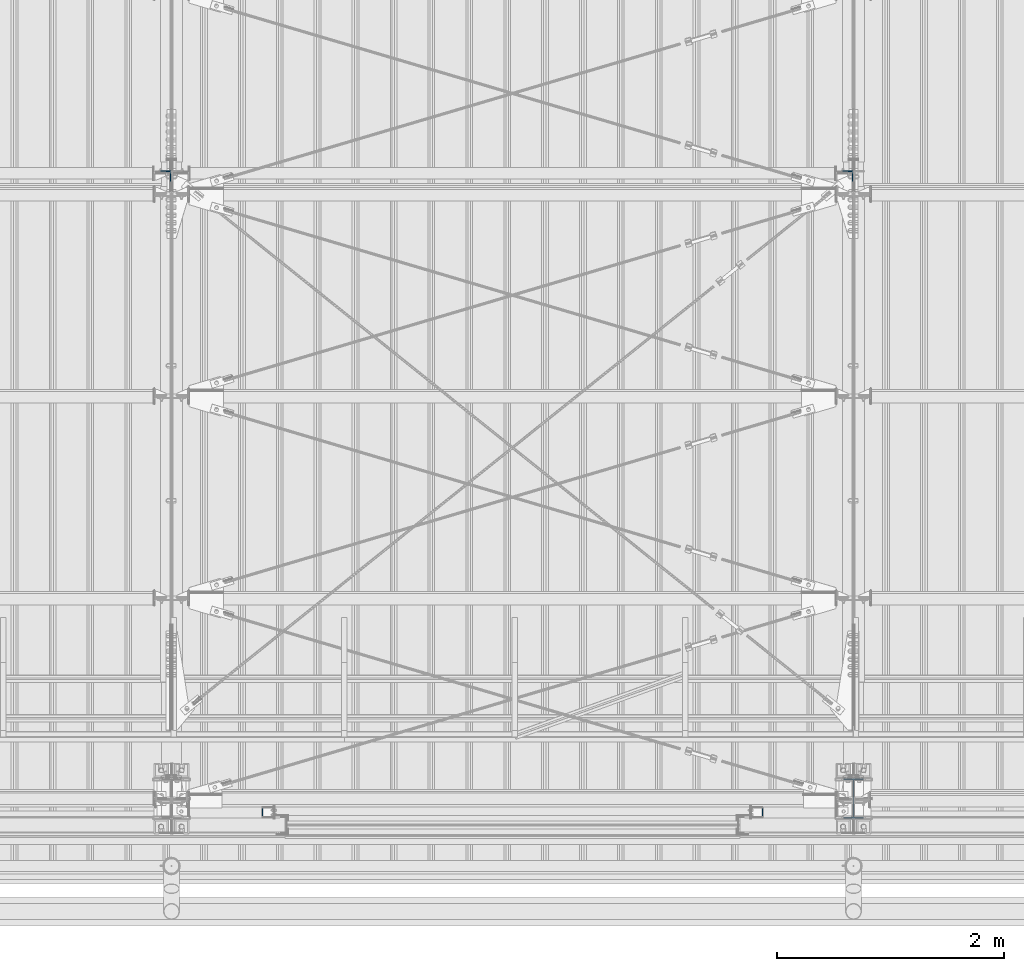
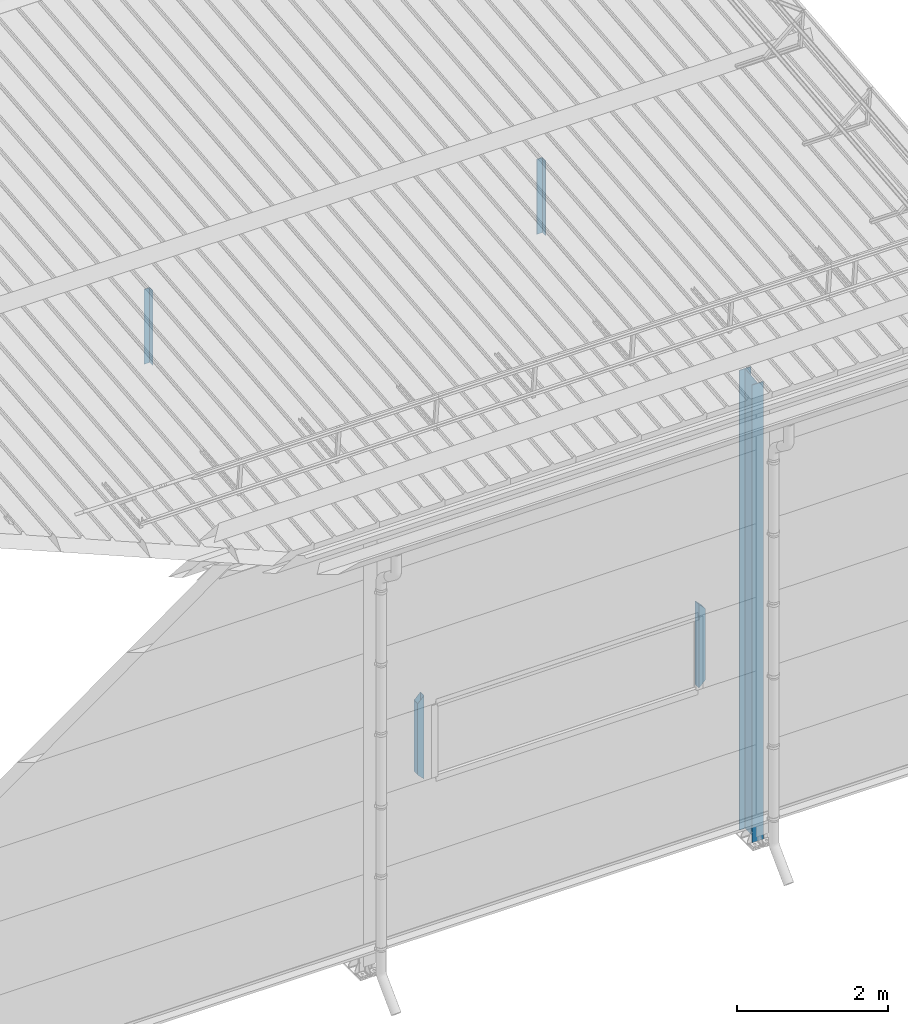
# One storey, part 235 of 709: 5 columns, 5 elements without a shape of their own.
"""IFC4 building model written with IfcOpenShell, lengths in millimetres."""

import ifcopenshell
import ifcopenshell.guid

model = None  # the IFC model being written
_history = None  # IfcOwnerHistory: only IFC2X3 demands one
_inside = {}  # id of a spatial element -> (the spatial element, [elements in it])
_under = {}  # id of a project, library or spatial element -> (it, [spatial elements below it])
_declared = {}  # id of a project -> (the project, [libraries it declares])
_typed = {}  # id of a type object -> (the type object, [elements of that type])
_made_of = {}  # id of a material, layer set ... -> (it, [elements and type objects made of it])


def new_model(schema):
    """Start an empty IFC model of exactly this schema.

    Asked for "IFC4X3", IfcOpenShell would pick the latest addendum, in which some entities
    have other attributes; the version numbers below select the first issue.
    IFC2X3 requires an IfcOwnerHistory on every rooted entity: one is made here for all.
    """
    global model, _history
    if schema == "IFC4X3":
        model = ifcopenshell.file(schema_version=(4, 3, 0, 0))
    else:
        model = ifcopenshell.file(schema=schema)
    _inside.clear()
    _under.clear()
    _declared.clear()
    _typed.clear()
    _made_of.clear()
    _history = None
    if model.schema == "IFC2X3":
        org = make("IfcOrganization", Name="unknown")
        user = make(
            "IfcPersonAndOrganization",
            ThePerson=make("IfcPerson", FamilyName="unknown"),
            TheOrganization=org,
        )
        app = make(
            "IfcApplication",
            ApplicationDeveloper=org,
            Version="unknown",
            ApplicationFullName="unknown",
            ApplicationIdentifier="unknown",
        )
        _history = make(
            "IfcOwnerHistory",
            OwningUser=user,
            OwningApplication=app,
            ChangeAction="ADDED",
            CreationDate=0,
        )
    return model


def make(cls, **values):
    """One entity of the class cls with the attributes given. An attribute that is None is left unset."""
    return model.create_entity(
        cls, **{name: value for name, value in values.items() if value is not None}
    )


def rooted(cls, **values):
    """An entity with a GlobalId (a new one), such as an element, a storey or a relation."""
    return make(cls, GlobalId=ifcopenshell.guid.new(), OwnerHistory=_history, **values)


def si_unit(unit_type, name, prefix=None):
    """IfcSIUnit, for example si_unit("LENGTHUNIT", "METRE", prefix="MILLI")."""
    return make("IfcSIUnit", UnitType=unit_type, Prefix=prefix, Name=name)


def assignment(units):
    """IfcUnitAssignment: the units of a project."""
    return None if units is None else make("IfcUnitAssignment", Units=units)


def point(xyz):
    """IfcCartesianPoint."""
    return None if xyz is None else make("IfcCartesianPoint", Coordinates=xyz)


def direction(xyz):
    """IfcDirection."""
    return None if xyz is None else make("IfcDirection", DirectionRatios=xyz)


def frame(location, z_axis=None, x_axis=None):
    """IfcAxis2Placement3D, a coordinate frame: its origin and axes. An axis left out is left unset."""
    return make(
        "IfcAxis2Placement3D",
        Location=point(location),
        Axis=direction(z_axis),
        RefDirection=direction(x_axis),
    )


def origin_with_axes():
    """The frame at (0, 0, 0) with the z axis (0, 0, 1) and the x axis (1, 0, 0) written out."""
    return frame((0.0, 0.0, 0.0), z_axis=(0.0, 0.0, 1.0), x_axis=(1.0, 0.0, 0.0))


def place(relative_to, where):
    """IfcLocalPlacement: puts the frame where relative to a parent placement (None: the world)."""
    return make(
        "IfcLocalPlacement", PlacementRelTo=relative_to, RelativePlacement=where
    )


def context(
    kind, dimensions, precision=None, world=None, true_north=None, identifier=None
):
    """IfcGeometricRepresentationContext, for example the 3D "Model" context."""
    return make(
        "IfcGeometricRepresentationContext",
        ContextIdentifier=identifier,
        ContextType=kind,
        CoordinateSpaceDimension=dimensions,
        Precision=precision,
        WorldCoordinateSystem=world,
        TrueNorth=true_north,
    )


def subcontext(parent, identifier, kind, view, scale=None):
    """IfcGeometricRepresentationSubContext, for example "Body" below "Model"."""
    return make(
        "IfcGeometricRepresentationSubContext",
        ContextIdentifier=identifier,
        ContextType=kind,
        ParentContext=parent,
        TargetScale=scale,
        TargetView=view,
    )


def project(units=None, contexts=None):
    """IfcProject with its units and contexts."""
    return rooted(
        "IfcProject",
        Name="project",
        RepresentationContexts=contexts,
        UnitsInContext=assignment(units),
    )


def spatial(cls, under=None, at=None, **own):
    """A site, building, storey or space (cls), placed at a placement, below another one or the project."""
    s = rooted(cls, ObjectPlacement=at, **own)
    if under is not None:
        _under.setdefault(under.id(), (under, []))[1].append(s)
    return s


def point_list(points):
    """IfcCartesianPointList2D or 3D."""
    cls = (
        "IfcCartesianPointList2D" if len(points[0]) == 2 else "IfcCartesianPointList3D"
    )
    return make(cls, CoordList=points)


def polygons(points, faces, closed=None, point_numbers=None):
    """IfcPolygonalFaceSet: a face is its outer loop, then its inner loops; points numbered from 1."""
    made = []
    for loops in faces:
        if len(loops) == 1:
            made.append(make("IfcIndexedPolygonalFace", CoordIndex=loops[0]))
        else:
            made.append(
                make(
                    "IfcIndexedPolygonalFaceWithVoids",
                    CoordIndex=loops[0],
                    InnerCoordIndices=loops[1:],
                )
            )
    return make(
        "IfcPolygonalFaceSet",
        Coordinates=point_list(points),
        Closed=closed,
        Faces=made,
        PnIndex=point_numbers,
    )


def shape(context_of_items, identifier, shape_type, items):
    """IfcShapeRepresentation: the items that make up one representation, for example the "Body"."""
    return make(
        "IfcShapeRepresentation",
        ContextOfItems=context_of_items,
        RepresentationIdentifier=identifier,
        RepresentationType=shape_type,
        Items=items,
    )


def material(Name=None, Category=None):
    """IfcMaterial."""
    return make("IfcMaterial", Name=Name, Category=Category)


def made_of(thing, what):
    """Note that an element or type object is made of a material, layer set ...; save() writes the relation."""
    if what is not None:
        _made_of.setdefault(what.id(), (what, []))[1].append(thing)
    return thing


def element(
    cls,
    number,
    at=None,
    inside=None,
    cuts=None,
    type_object=None,
    material=None,
    context=None,
    identifier="Body",
    shape_type=None,
    held_by="IfcProductDefinitionShape",
    body=None,
    shapes=None,
    **own,
):
    """One element of the class cls, such as IfcWall. Its Tag is "e" and its number.

    at: its placement. inside: the storey or other place that contains it. cuts: it is an
    opening in that element (IfcRelVoidsElement). A single representation is given by context,
    identifier, shape_type and body (its items); several are given by shapes. held_by: the class
    of the entity that holds the representations. save() writes the other relations.
    """
    e = rooted(cls, Tag="e%d" % number, ObjectPlacement=at, **own)
    if body is not None:
        shapes = [shape(context, identifier, shape_type, body)]
    if shapes is not None:
        e.Representation = make(held_by, Representations=shapes)
    if inside is not None:
        _inside.setdefault(inside.id(), (inside, []))[1].append(e)
    if cuts is not None:
        rooted(
            "IfcRelVoidsElement", RelatingBuildingElement=cuts, RelatedOpeningElement=e
        )
    if type_object is not None:
        _typed.setdefault(type_object.id(), (type_object, []))[1].append(e)
    return made_of(e, material)


def aggregate(whole, parts):
    """IfcRelAggregates: a whole, such as a stair, and the parts it consists of."""
    return rooted("IfcRelAggregates", RelatingObject=whole, RelatedObjects=parts)


def save(model, path):
    """Write the relations noted so far, then the file.

    IfcRelAggregates (storeys below a building ...), IfcRelContainedInSpatialStructure (elements
    in a storey), IfcRelDefinesByType, IfcRelAssociatesMaterial and IfcRelDeclares: one each for
    every whole, place, type object, material and project.
    """
    for whole, parts in _under.values():
        aggregate(whole, parts)
    for where, things in _inside.values():
        rooted(
            "IfcRelContainedInSpatialStructure",
            RelatedElements=things,
            RelatingStructure=where,
        )
    for kind, things in _typed.values():
        rooted("IfcRelDefinesByType", RelatedObjects=things, RelatingType=kind)
    for what, things in _made_of.values():
        rooted("IfcRelAssociatesMaterial", RelatedObjects=things, RelatingMaterial=what)
    for by, libraries in _declared.values():
        rooted("IfcRelDeclares", RelatingContext=by, RelatedDefinitions=libraries)
    model.write(path)


model = new_model("IFC4")

# Units and contexts
model_context = context("Model", 3, precision=0.2, world=origin_with_axes(), true_north=direction((0.0, 1.0)))
body_context = subcontext(model_context, "Body", "Model", "MODEL_VIEW")
ifc_project = project(units=[si_unit("LENGTHUNIT", "METRE", prefix="MILLI"), si_unit("AREAUNIT", "SQUARE_METRE"), si_unit("VOLUMEUNIT", "CUBIC_METRE"), si_unit("MASSUNIT", "GRAM", prefix="KILO"), si_unit("TIMEUNIT", "SECOND"), si_unit("PLANEANGLEUNIT", "RADIAN"), si_unit("SOLIDANGLEUNIT", "STERADIAN"), si_unit("THERMODYNAMICTEMPERATUREUNIT", "DEGREE_CELSIUS"), si_unit("LUMINOUSINTENSITYUNIT", "LUMEN")], contexts=[model_context])

# Site, building, storey
site_placement = place(None, origin_with_axes())
site = spatial("IfcSite", under=ifc_project, at=site_placement, CompositionType="ELEMENT")
building_placement = place(site_placement, origin_with_axes())
building = spatial("IfcBuilding", under=site, at=building_placement, Name="Undefined", CompositionType="ELEMENT")
storey_placement = place(building_placement, origin_with_axes())
storey = spatial("IfcBuildingStorey", under=building, at=storey_placement, Name="Undefined", CompositionType="ELEMENT", Elevation=0.0)

# Assembly, column
assembly_1_placement = place(storey_placement, frame((46000.0, 173.0, -200.0), z_axis=(-1.0, 0.0, 0.0), x_axis=(0.0, 0.0, 1.0)))
assembly_1 = element("IfcElementAssembly", 1, at=assembly_1_placement, inside=storey)
ifc_material_1 = material(Name="C355-5", Category="STEEL")
column_1_placement = place(assembly_1_placement, origin_with_axes())
column_1 = element("IfcColumn", 2, at=column_1_placement, material=ifc_material_1, ObjectType="413", context=body_context, shape_type="Tessellation", body=[
    polygons([(25.0, -173.0, -87.0), (25.0, -164.0, -87.0), (7421.82297, -164.0, -87.0), (7420.92297, -173.0, -87.0), (25.0, -164.0, -3.0), (7421.82297, -164.0, -3.0), (25.0, 164.0, -3.0), (7454.62297, 164.0, -3.0), (25.0, 164.0, -87.0), (7454.62297, 164.0, -87.0), (25.0, 173.0, -87.0), (7455.52297, 173.0, -87.0), (25.0, 173.0, 87.0), (7455.52297, 173.0, 87.0), (25.0, 164.0, 87.0), (7454.62297, 164.0, 87.0), (25.0, 164.0, 3.0), (7454.62297, 164.0, 3.0), (25.0, -164.0, 3.0), (7421.82297, -164.0, 3.0), (25.0, -164.0, 87.0), (7421.82297, -164.0, 87.0), (25.0, -173.0, 87.0), (7420.92297, -173.0, 87.0)], [[[1, 2, 3, 4]], [[2, 5, 6, 3]], [[5, 7, 8, 6]], [[7, 9, 10, 8]], [[9, 11, 12, 10]], [[11, 13, 14, 12]], [[13, 15, 16, 14]], [[15, 17, 18, 16]], [[17, 19, 20, 18]], [[19, 21, 22, 20]], [[21, 23, 24, 22]], [[23, 1, 4, 24]], [[6, 8, 10, 12, 14, 16, 18, 20, 22, 24, 4, 3]], [[23, 21, 19, 17, 15, 13, 11, 9, 7, 5, 2, 1]]], closed=True),
])
aggregate(assembly_1, [column_1])

assembly_2_placement = place(storey_placement, frame((39949.0, 5648.7, 6024.30002), z_axis=(0.0, -1.0, 0.0), x_axis=(0.0, 0.0, 1.0)))
assembly_2 = element("IfcElementAssembly", 3, at=assembly_2_placement, inside=storey)
ifc_material_2 = material(Name="C345-5", Category="STEEL")
column_2_placement = place(assembly_2_placement, origin_with_axes())
column_2 = element("IfcColumn", 4, at=column_2_placement, material=ifc_material_2, ObjectType="436", context=body_context, shape_type="Tessellation", body=[
    polygons([(185.7, -45.0, -45.0), (185.7, 45.0, -45.0), (1399.0509, 45.0, -45.0), (1399.0509, -45.0, -45.0), (185.7, 45.0, -39.0), (1399.0509, 45.0, -39.0), (185.7, -39.0, -39.0), (1399.0509, -39.0, -39.0), (185.7, -39.0, 45.0), (1399.0509, -39.0, 45.0), (185.7, -45.0, 45.0), (1399.0509, -45.0, 45.0)], [[[1, 2, 3, 4]], [[2, 5, 6, 3]], [[5, 7, 8, 6]], [[7, 9, 10, 8]], [[9, 11, 12, 10]], [[11, 1, 4, 12]], [[6, 8, 10, 12, 4, 3]], [[11, 9, 7, 5, 2, 1]]], closed=True),
])
aggregate(assembly_2, [column_2])

assembly_3_placement = place(storey_placement, frame((45949.0, 5648.7, 6024.30002), z_axis=(0.0, -1.0, 0.0), x_axis=(0.0, 0.0, 1.0)))
assembly_3 = element("IfcElementAssembly", 5, at=assembly_3_placement, inside=storey)
column_3_placement = place(assembly_3_placement, origin_with_axes())
column_3 = element("IfcColumn", 6, at=column_3_placement, material=ifc_material_2, ObjectType="436", context=body_context, shape_type="Tessellation", body=[
    polygons([(185.7, -45.0, -45.0), (185.7, 45.0, -45.0), (1399.0509, 45.0, -45.0), (1399.0509, -45.0, -45.0), (185.7, 45.0, -39.0), (1399.0509, 45.0, -39.0), (185.7, -39.0, -39.0), (1399.0509, -39.0, -39.0), (185.7, -39.0, 45.0), (1399.0509, -39.0, 45.0), (185.7, -45.0, 45.0), (1399.0509, -45.0, 45.0)], [[[1, 2, 3, 4]], [[2, 5, 6, 3]], [[5, 7, 8, 6]], [[7, 9, 10, 8]], [[9, 11, 12, 10]], [[11, 1, 4, 12]], [[6, 8, 10, 12, 4, 3]], [[11, 9, 7, 5, 2, 1]]], closed=True),
])
aggregate(assembly_3, [column_3])

assembly_4_placement = place(storey_placement, frame((40850.0, 50.0, 2600.0), z_axis=(1.0, 0.0, 0.0), x_axis=(0.0, 0.0, 1.0)))
assembly_4 = element("IfcElementAssembly", 7, at=assembly_4_placement, inside=storey)
ifc_material_3 = material(Name="C355", Category="STEEL")
column_4_placement = place(assembly_4_placement, origin_with_axes())
column_4 = element("IfcColumn", 8, at=column_4_placement, material=ifc_material_3, ObjectType="493", context=body_context, shape_type="Tessellation", body=[
    polygons([(10.0, -50.0, 50.0), (110.0, -50.0, -50.0), (1260.0, -50.0, -50.0), (1360.0, -50.0, 50.0), (10.0, 50.0, 50.0), (1360.0, 50.0, 50.0), (110.0, 50.0, -50.0), (1260.0, 50.0, -50.0), (13.0, -47.0, 47.0), (13.0, 47.0, 47.0), (1357.0, 47.0, 47.0), (1357.0, -47.0, 47.0), (107.0, -47.0, -47.0), (1263.0, -47.0, -47.0), (107.0, 47.0, -47.0), (1263.0, 47.0, -47.0)], [[[1, 2, 3, 4]], [[5, 1, 4, 6]], [[7, 5, 6, 8]], [[2, 7, 8, 3]], [[1, 5, 7, 2], [9, 13, 15, 10]], [[9, 10, 11, 12]], [[13, 9, 12, 14]], [[15, 13, 14, 16]], [[10, 15, 16, 11]], [[3, 8, 6, 4], [14, 12, 11, 16]]], closed=True),
])
aggregate(assembly_4, [column_4])

assembly_5_placement = place(storey_placement, frame((45150.0, 50.0, 2600.0), z_axis=(1.0, 0.0, 0.0), x_axis=(0.0, 0.0, 1.0)))
assembly_5 = element("IfcElementAssembly", 9, at=assembly_5_placement, inside=storey)
column_5_placement = place(assembly_5_placement, origin_with_axes())
column_5 = element("IfcColumn", 10, at=column_5_placement, material=ifc_material_3, ObjectType="493", context=body_context, shape_type="Tessellation", body=[
    polygons([(10.0, -50.0, -50.0), (10.0, 50.0, -50.0), (1360.0, 50.0, -50.0), (1360.0, -50.0, -50.0), (110.0, -50.0, 50.0), (1260.0, -50.0, 50.0), (110.0, 50.0, 50.0), (1260.0, 50.0, 50.0), (107.0, 47.0, 47.0), (13.0, 47.0, -47.0), (1357.0, 47.0, -47.0), (1263.0, 47.0, 47.0), (107.0, -47.0, 47.0), (1263.0, -47.0, 47.0), (13.0, -47.0, -47.0), (1357.0, -47.0, -47.0)], [[[1, 2, 3, 4]], [[5, 1, 4, 6]], [[7, 5, 6, 8]], [[2, 7, 8, 3]], [[1, 5, 7, 2], [15, 10, 9, 13]], [[9, 10, 11, 12]], [[13, 9, 12, 14]], [[15, 13, 14, 16]], [[10, 15, 16, 11]], [[6, 4, 3, 8], [14, 12, 11, 16]]], closed=True),
])
aggregate(assembly_5, [column_5])

save(model, "model.ifc")
